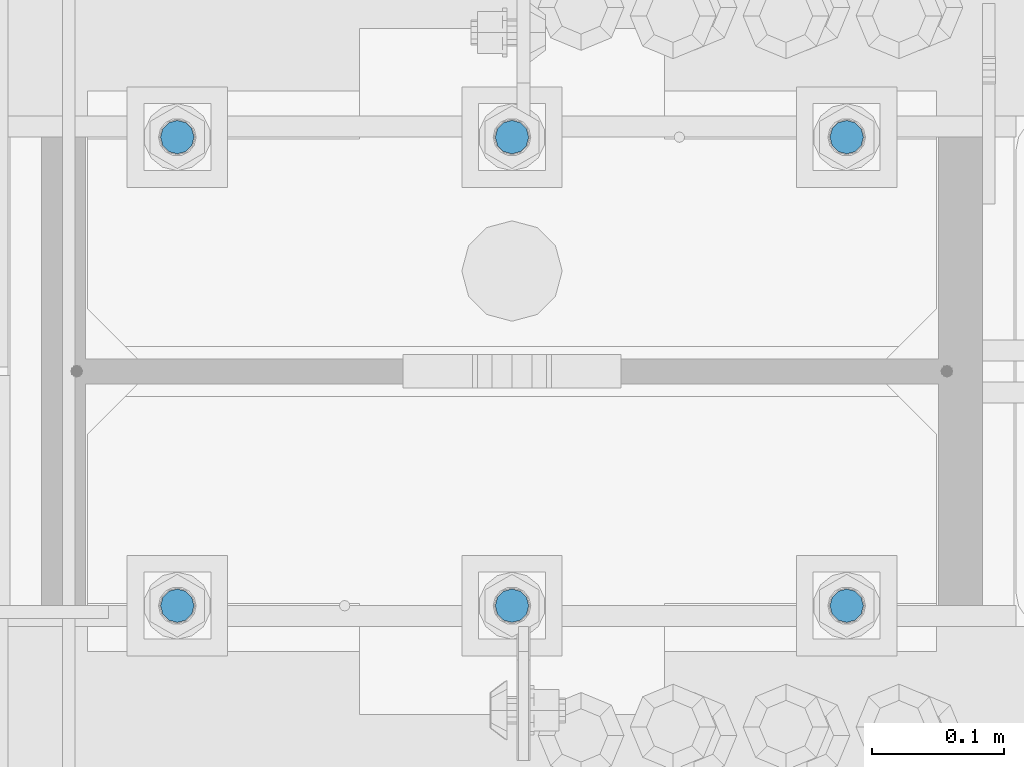
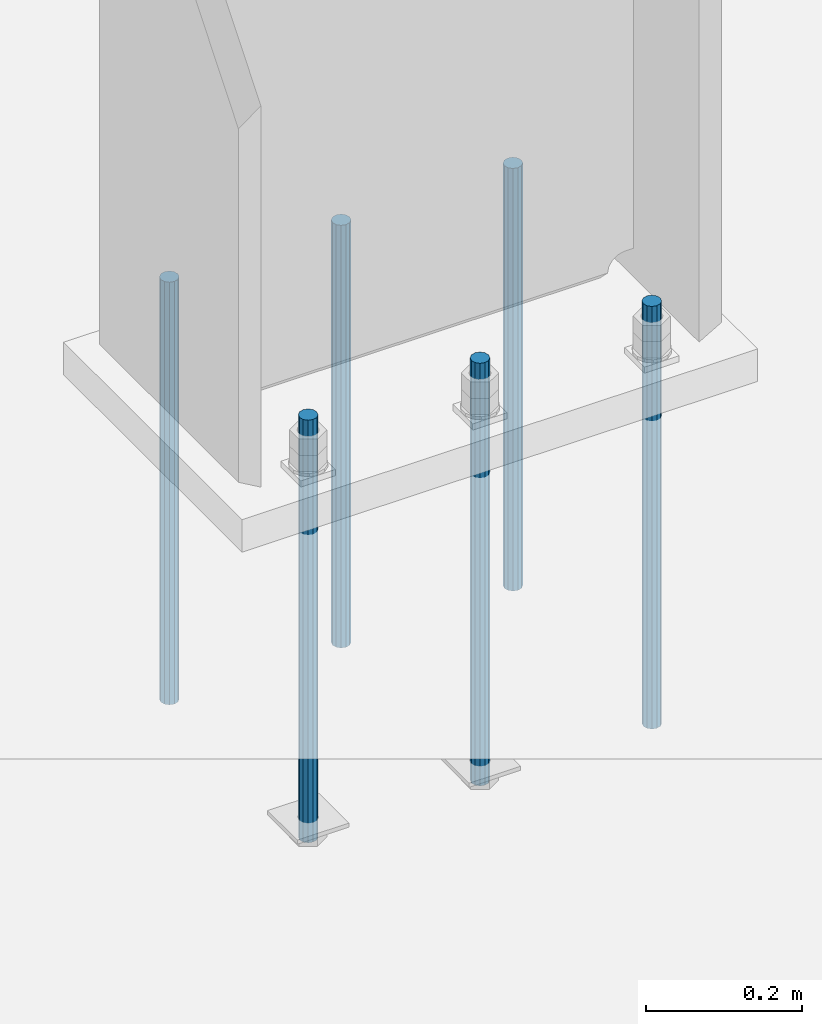
# One storey, part 951 of 1763: 6 columns, 1 element without a shape of its own.
"""IFC2X3 building model written with IfcOpenShell, lengths in millimetres."""

from ifc_helpers import new_model, si_unit, frame, origin_with_axes, place, context, subcontext, project, spatial, faceted_brep, material, type_object, element, aggregate, save


model = new_model("IFC2X3")

# Units and contexts
model_context = context("Model", 3, precision=1e-05, world=origin_with_axes())
body_context = subcontext(model_context, "Body", "Model", "MODEL_VIEW")
ifc_project = project(units=[si_unit("LENGTHUNIT", "METRE", prefix="MILLI"), si_unit("AREAUNIT", "SQUARE_METRE"), si_unit("VOLUMEUNIT", "CUBIC_METRE"), si_unit("MASSUNIT", "GRAM", prefix="KILO"), si_unit("TIMEUNIT", "SECOND"), si_unit("PLANEANGLEUNIT", "RADIAN"), si_unit("SOLIDANGLEUNIT", "STERADIAN"), si_unit("THERMODYNAMICTEMPERATUREUNIT", "DEGREE_CELSIUS"), si_unit("LUMINOUSINTENSITYUNIT", "LUMEN")], contexts=[model_context])

# Site, building, storey
site_placement = place(None, origin_with_axes())
site = spatial("IfcSite", under=ifc_project, at=site_placement, CompositionType="ELEMENT")
building_placement = place(site_placement, origin_with_axes())
building = spatial("IfcBuilding", under=site, at=building_placement, Name="Undefined", CompositionType="ELEMENT")
storey_placement = place(building_placement, origin_with_axes())
storey = spatial("IfcBuildingStorey", under=building, at=storey_placement, Name="Undefined", CompositionType="ELEMENT", Elevation=0.0)

# Assembly, columns
assembly_placement = place(storey_placement, origin_with_axes())
assembly = element("IfcElementAssembly", 1, at=assembly_placement, inside=storey, Name="TEMPLATE", AssemblyPlace="NOTDEFINED", PredefinedType="RIGID_FRAME")
ifc_material = material(Name="STEEL/F1554-55")
column_type = type_object("IfcColumnType", PredefinedType="NOTDEFINED")
column_1_placement = place(assembly_placement, frame((-87121.4372736983, 51943.0, -127.000000000016), z_axis=(1.0, 0.0, 0.0), x_axis=(0.0, 0.0, -1.0)))
column_1 = element("IfcColumn", 2, at=column_1_placement, type_object=column_type, material=ifc_material, Name="ALL THREADED ROD", context=body_context, shape_type="Brep", body=[
    faceted_brep([(0.0, -12.6999999999971, -1.81898940354586e-12), (0.0, -10.9985226280623, -6.35000000000582), (660.399, -10.9985226280623, -6.35000000000582), (660.399, -12.6999999999971, 0.0), (0.0, -6.34999999999854, -10.9985226280696), (660.399, -6.34999999999854, -10.9985226280696), (3.63797880709171e-12, 0.0, -12.6999998092651), (660.399, 0.0, -12.6999999999971), (0.0, 6.34999999999854, -10.9985226280696), (660.399, 6.34999999999854, -10.9985226280696), (0.0, 10.9985226280623, -6.35000000000582), (660.399, 10.9985226280623, -6.35000000000582), (0.0, 12.6999999999971, -1.81898940354586e-12), (660.399, 12.6999999999971, 0.0), (0.0, 10.9985226280623, 6.35000000000582), (660.399, 10.9985226280623, 6.35000000000582), (0.0, 6.34999999999854, 10.9985226280696), (660.399, 6.34999999999854, 10.9985226280696), (-3.63797880709171e-12, 0.0, 12.6999998092651), (660.399, 0.0, 12.6999999999971), (0.0, -6.34999999999854, 10.9985226280696), (660.399, -6.34999999999854, 10.9985226280696), (0.0, -10.9985226280623, 6.35000000000582), (660.399, -10.9985226280623, 6.35000000000582)], [[[0, 1, 2, 3]], [[1, 4, 5, 2]], [[4, 6, 7, 5]], [[6, 8, 9, 7]], [[8, 10, 11, 9]], [[10, 12, 13, 11]], [[12, 14, 15, 13]], [[14, 16, 17, 15]], [[16, 18, 19, 17]], [[18, 20, 21, 19]], [[20, 22, 23, 21]], [[22, 0, 3, 23]], [[5, 7, 9, 11, 13, 15, 17, 19, 21, 23, 3, 2]], [[22, 20, 18, 16, 14, 12, 10, 8, 6, 4, 1, 0]]]),
])
column_2_placement = place(assembly_placement, frame((-87121.4372736983, 52298.6, -127.000000000016), z_axis=(-1.0, 0.0, 0.0), x_axis=(0.0, 0.0, -1.0)))
column_2 = element("IfcColumn", 3, at=column_2_placement, type_object=column_type, material=ifc_material, Name="ALL THREADED ROD", context=body_context, shape_type="Brep", body=[
    faceted_brep([(0.0, -12.6999999999971, -1.81898940354586e-12), (0.0, -10.9985226280623, -6.35000000000582), (660.399, -10.9985226280623, -6.35000000000582), (660.399, -12.6999999999971, 0.0), (0.0, -6.34999999999854, -10.9985226280696), (660.399, -6.34999999999854, -10.9985226280696), (3.63797880709171e-12, 0.0, -12.6999998092651), (660.399, 0.0, -12.6999999999971), (0.0, 6.34999999999854, -10.9985226280696), (660.399, 6.34999999999854, -10.9985226280696), (0.0, 10.9985226280623, -6.35000000000582), (660.399, 10.9985226280623, -6.35000000000582), (0.0, 12.6999999999971, -1.81898940354586e-12), (660.399, 12.6999999999971, 0.0), (0.0, 10.9985226280623, 6.35000000000582), (660.399, 10.9985226280623, 6.35000000000582), (0.0, 6.34999999999854, 10.9985226280696), (660.399, 6.34999999999854, 10.9985226280696), (-3.63797880709171e-12, 0.0, 12.6999998092651), (660.399, 0.0, 12.6999999999971), (0.0, -6.34999999999854, 10.9985226280696), (660.399, -6.34999999999854, 10.9985226280696), (0.0, -10.9985226280623, 6.35000000000582), (660.399, -10.9985226280623, 6.35000000000582)], [[[0, 1, 2, 3]], [[1, 4, 5, 2]], [[4, 6, 7, 5]], [[6, 8, 9, 7]], [[8, 10, 11, 9]], [[10, 12, 13, 11]], [[12, 14, 15, 13]], [[14, 16, 17, 15]], [[16, 18, 19, 17]], [[18, 20, 21, 19]], [[20, 22, 23, 21]], [[22, 0, 3, 23]], [[5, 7, 9, 11, 13, 15, 17, 19, 21, 23, 3, 2]], [[22, 20, 18, 16, 14, 12, 10, 8, 6, 4, 1, 0]]]),
])
column_3_placement = place(assembly_placement, frame((-87375.4372736983, 51943.0, -127.000000000016), z_axis=(1.0, 0.0, 0.0), x_axis=(0.0, 0.0, -1.0)))
column_3 = element("IfcColumn", 4, at=column_3_placement, type_object=column_type, material=ifc_material, Name="ALL THREADED ROD", context=body_context, shape_type="Brep", body=[
    faceted_brep([(0.0, -12.6999999999971, -1.81898940354586e-12), (0.0, -10.9985226280623, -6.35000000000582), (660.399, -10.9985226280623, -6.35000000000582), (660.399, -12.6999999999971, 0.0), (0.0, -6.34999999999854, -10.9985226280696), (660.399, -6.34999999999854, -10.9985226280696), (3.63797880709171e-12, 0.0, -12.6999998092651), (660.399, 0.0, -12.6999999999971), (0.0, 6.34999999999854, -10.9985226280696), (660.399, 6.34999999999854, -10.9985226280696), (0.0, 10.9985226280623, -6.35000000000582), (660.399, 10.9985226280623, -6.35000000000582), (0.0, 12.6999999999971, -1.81898940354586e-12), (660.399, 12.6999999999971, 0.0), (0.0, 10.9985226280623, 6.35000000000582), (660.399, 10.9985226280623, 6.35000000000582), (0.0, 6.34999999999854, 10.9985226280696), (660.399, 6.34999999999854, 10.9985226280696), (-3.63797880709171e-12, 0.0, 12.6999998092651), (660.399, 0.0, 12.6999999999971), (0.0, -6.34999999999854, 10.9985226280696), (660.399, -6.34999999999854, 10.9985226280696), (0.0, -10.9985226280623, 6.35000000000582), (660.399, -10.9985226280623, 6.35000000000582)], [[[0, 1, 2, 3]], [[1, 4, 5, 2]], [[4, 6, 7, 5]], [[6, 8, 9, 7]], [[8, 10, 11, 9]], [[10, 12, 13, 11]], [[12, 14, 15, 13]], [[14, 16, 17, 15]], [[16, 18, 19, 17]], [[18, 20, 21, 19]], [[20, 22, 23, 21]], [[22, 0, 3, 23]], [[5, 7, 9, 11, 13, 15, 17, 19, 21, 23, 3, 2]], [[22, 20, 18, 16, 14, 12, 10, 8, 6, 4, 1, 0]]]),
])
column_4_placement = place(assembly_placement, frame((-87375.4372736983, 52298.6, -127.000000000016), z_axis=(-1.0, 0.0, 0.0), x_axis=(0.0, 0.0, -1.0)))
column_4 = element("IfcColumn", 5, at=column_4_placement, type_object=column_type, material=ifc_material, Name="ALL THREADED ROD", context=body_context, shape_type="Brep", body=[
    faceted_brep([(0.0, -12.6999999999971, -1.81898940354586e-12), (0.0, -10.9985226280623, -6.35000000000582), (660.399, -10.9985226280623, -6.35000000000582), (660.399, -12.6999999999971, 0.0), (0.0, -6.34999999999854, -10.9985226280696), (660.399, -6.34999999999854, -10.9985226280696), (3.63797880709171e-12, 0.0, -12.6999998092651), (660.399, 0.0, -12.6999999999971), (0.0, 6.34999999999854, -10.9985226280696), (660.399, 6.34999999999854, -10.9985226280696), (0.0, 10.9985226280623, -6.35000000000582), (660.399, 10.9985226280623, -6.35000000000582), (0.0, 12.6999999999971, -1.81898940354586e-12), (660.399, 12.6999999999971, 0.0), (0.0, 10.9985226280623, 6.35000000000582), (660.399, 10.9985226280623, 6.35000000000582), (0.0, 6.34999999999854, 10.9985226280696), (660.399, 6.34999999999854, 10.9985226280696), (-3.63797880709171e-12, 0.0, 12.6999998092651), (660.399, 0.0, 12.6999999999971), (0.0, -6.34999999999854, 10.9985226280696), (660.399, -6.34999999999854, 10.9985226280696), (0.0, -10.9985226280623, 6.35000000000582), (660.399, -10.9985226280623, 6.35000000000582)], [[[0, 1, 2, 3]], [[1, 4, 5, 2]], [[4, 6, 7, 5]], [[6, 8, 9, 7]], [[8, 10, 11, 9]], [[10, 12, 13, 11]], [[12, 14, 15, 13]], [[14, 16, 17, 15]], [[16, 18, 19, 17]], [[18, 20, 21, 19]], [[20, 22, 23, 21]], [[22, 0, 3, 23]], [[5, 7, 9, 11, 13, 15, 17, 19, 21, 23, 3, 2]], [[22, 20, 18, 16, 14, 12, 10, 8, 6, 4, 1, 0]]]),
])
column_5_placement = place(assembly_placement, frame((-87629.4372736983, 51943.0, -127.000000000016), z_axis=(1.0, 0.0, 0.0), x_axis=(0.0, 0.0, -1.0)))
column_5 = element("IfcColumn", 6, at=column_5_placement, type_object=column_type, material=ifc_material, Name="ALL THREADED ROD", context=body_context, shape_type="Brep", body=[
    faceted_brep([(0.0, -12.6999999999971, -1.81898940354586e-12), (0.0, -10.9985226280623, -6.35000000000582), (660.399, -10.9985226280623, -6.35000000000582), (660.399, -12.6999999999971, 0.0), (0.0, -6.34999999999854, -10.9985226280696), (660.399, -6.34999999999854, -10.9985226280696), (3.63797880709171e-12, 0.0, -12.6999998092651), (660.399, 0.0, -12.6999999999971), (0.0, 6.34999999999854, -10.9985226280696), (660.399, 6.34999999999854, -10.9985226280696), (0.0, 10.9985226280623, -6.35000000000582), (660.399, 10.9985226280623, -6.35000000000582), (0.0, 12.6999999999971, -1.81898940354586e-12), (660.399, 12.6999999999971, 0.0), (0.0, 10.9985226280623, 6.35000000000582), (660.399, 10.9985226280623, 6.35000000000582), (0.0, 6.34999999999854, 10.9985226280696), (660.399, 6.34999999999854, 10.9985226280696), (-3.63797880709171e-12, 0.0, 12.6999998092651), (660.399, 0.0, 12.6999999999971), (0.0, -6.34999999999854, 10.9985226280696), (660.399, -6.34999999999854, 10.9985226280696), (0.0, -10.9985226280623, 6.35000000000582), (660.399, -10.9985226280623, 6.35000000000582)], [[[0, 1, 2, 3]], [[1, 4, 5, 2]], [[4, 6, 7, 5]], [[6, 8, 9, 7]], [[8, 10, 11, 9]], [[10, 12, 13, 11]], [[12, 14, 15, 13]], [[14, 16, 17, 15]], [[16, 18, 19, 17]], [[18, 20, 21, 19]], [[20, 22, 23, 21]], [[22, 0, 3, 23]], [[5, 7, 9, 11, 13, 15, 17, 19, 21, 23, 3, 2]], [[22, 20, 18, 16, 14, 12, 10, 8, 6, 4, 1, 0]]]),
])
column_6_placement = place(assembly_placement, frame((-87629.4372736983, 52298.6, -127.000000000016), z_axis=(-1.0, 0.0, 0.0), x_axis=(0.0, 0.0, -1.0)))
column_6 = element("IfcColumn", 7, at=column_6_placement, type_object=column_type, material=ifc_material, Name="ALL THREADED ROD", context=body_context, shape_type="Brep", body=[
    faceted_brep([(0.0, -12.6999999999971, -1.81898940354586e-12), (0.0, -10.9985226280623, -6.35000000000582), (660.399, -10.9985226280623, -6.35000000000582), (660.399, -12.6999999999971, 0.0), (0.0, -6.34999999999854, -10.9985226280696), (660.399, -6.34999999999854, -10.9985226280696), (3.63797880709171e-12, 0.0, -12.6999998092651), (660.399, 0.0, -12.6999999999971), (0.0, 6.34999999999854, -10.9985226280696), (660.399, 6.34999999999854, -10.9985226280696), (0.0, 10.9985226280623, -6.35000000000582), (660.399, 10.9985226280623, -6.35000000000582), (0.0, 12.6999999999971, -1.81898940354586e-12), (660.399, 12.6999999999971, 0.0), (0.0, 10.9985226280623, 6.35000000000582), (660.399, 10.9985226280623, 6.35000000000582), (0.0, 6.34999999999854, 10.9985226280696), (660.399, 6.34999999999854, 10.9985226280696), (-3.63797880709171e-12, 0.0, 12.6999998092651), (660.399, 0.0, 12.6999999999971), (0.0, -6.34999999999854, 10.9985226280696), (660.399, -6.34999999999854, 10.9985226280696), (0.0, -10.9985226280623, 6.35000000000582), (660.399, -10.9985226280623, 6.35000000000582)], [[[0, 1, 2, 3]], [[1, 4, 5, 2]], [[4, 6, 7, 5]], [[6, 8, 9, 7]], [[8, 10, 11, 9]], [[10, 12, 13, 11]], [[12, 14, 15, 13]], [[14, 16, 17, 15]], [[16, 18, 19, 17]], [[18, 20, 21, 19]], [[20, 22, 23, 21]], [[22, 0, 3, 23]], [[5, 7, 9, 11, 13, 15, 17, 19, 21, 23, 3, 2]], [[22, 20, 18, 16, 14, 12, 10, 8, 6, 4, 1, 0]]]),
])
aggregate(assembly, [column_1, column_2, column_3, column_4, column_5, column_6])

save(model, "model.ifc")
